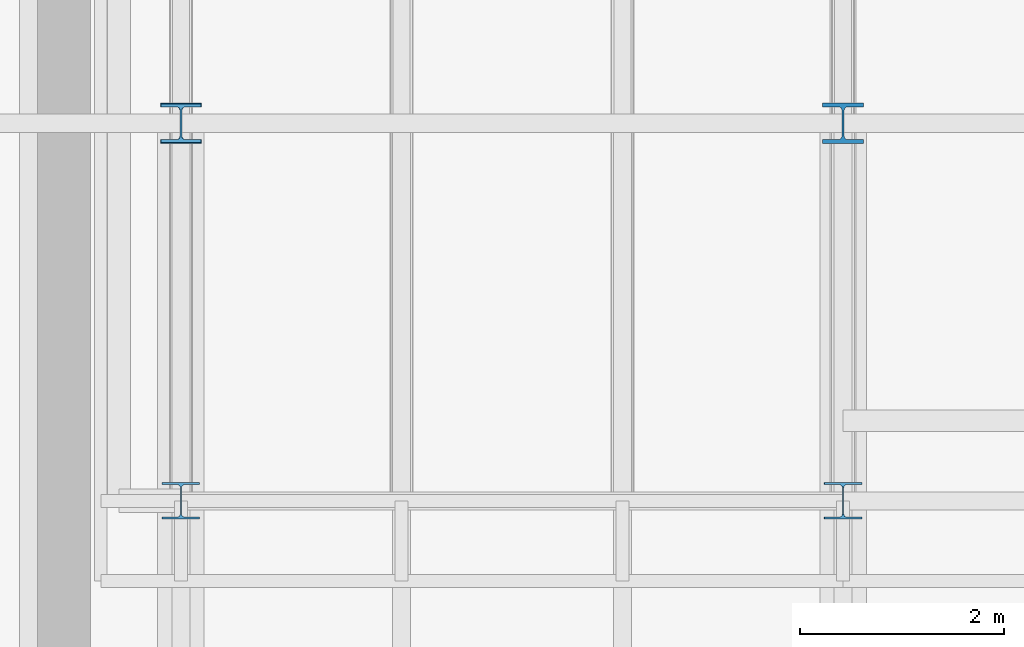
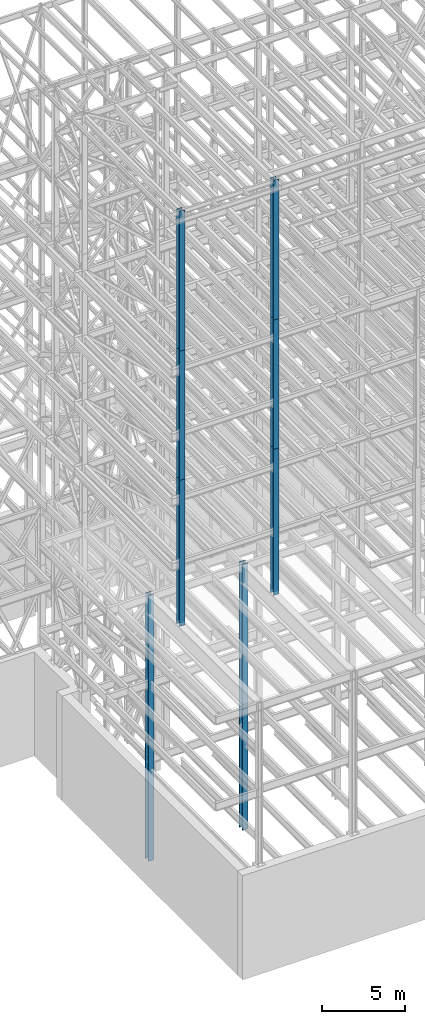
# One storey, part 2 of 150: 10 columns.
"""IFC2X3 building model written with IfcOpenShell, lengths in millimetres."""

from ifc_helpers import new_model, si_unit, frame, origin_with_axes, origin_2d_with_axis, place, context, subcontext, project, spatial, i_section, extrude, material, type_object, element, save


model = new_model("IFC2X3")

# Units and contexts
model_context = context("Model", 3, precision=1e-05, world=origin_with_axes())
body_context = subcontext(model_context, "Body", "Model", "MODEL_VIEW")
ifc_project = project(units=[si_unit("LENGTHUNIT", "METRE", prefix="MILLI"), si_unit("AREAUNIT", "SQUARE_METRE"), si_unit("VOLUMEUNIT", "CUBIC_METRE"), si_unit("MASSUNIT", "GRAM", prefix="KILO"), si_unit("TIMEUNIT", "SECOND"), si_unit("PLANEANGLEUNIT", "RADIAN"), si_unit("SOLIDANGLEUNIT", "STERADIAN"), si_unit("THERMODYNAMICTEMPERATUREUNIT", "DEGREE_CELSIUS"), si_unit("LUMINOUSINTENSITYUNIT", "LUMEN")], contexts=[model_context])

# Site, building, storey
site_placement = place(None, origin_with_axes())
site = spatial("IfcSite", under=ifc_project, at=site_placement, CompositionType="ELEMENT")
building_placement = place(site_placement, origin_with_axes())
building = spatial("IfcBuilding", under=site, at=building_placement, Name="Undefined", CompositionType="ELEMENT")
storey_placement = place(building_placement, origin_with_axes())
storey = spatial("IfcBuildingStorey", under=building, at=storey_placement, Name="Undefined", CompositionType="ELEMENT", Elevation=0.0)

# Columns
ifc_material = material(Name="STEEL/A992")
column_type_1 = type_object("IfcColumnType", Name="W14X193", PredefinedType="NOTDEFINED")
column_1_placement = place(storey_placement, frame((11785.6, 13106.4, 24993.6), z_axis=(0.0, 0.0, 1.0), x_axis=(1.0, 0.0, 0.0)))
element("IfcColumn", 1, at=column_1_placement, inside=storey, type_object=column_type_1, material=ifc_material, Name="COLUMN", ObjectType="W14X193", context=body_context, shape_type="SweptSolid", body=[
    extrude(i_section(OverallWidth=400.05, OverallDepth=393.7, WebThickness=22.225, FlangeThickness=36.576, FilletRadius=33.2739, at=origin_2d_with_axis()), frame((0.0, 0.0, 10591.8), z_axis=(0.0, 0.0, -1.0), x_axis=(-1.0, 0.0, 0.0)), (0.0, 0.0, 1.0), 10591.8),
])
for number, where, z_axis, x_axis, name in (
    (2, (11785.6, 13106.4, 16154.4), (0.0, 0.0, 1.0), (1.0, 0.0, 0.0), "COLUMN"),
    (3, (5283.2, 13106.4, 16154.4), (0.0, 0.0, 1.0), (1.0, 0.0, 0.0), "COLUMN"),
):
    element("IfcColumn", number, at=place(storey_placement, frame(where, z_axis=z_axis, x_axis=x_axis)), inside=storey, type_object=column_type_1, material=ifc_material, Name=name, ObjectType="W14X193", context=body_context, shape_type="SweptSolid", body=[
        extrude(i_section(OverallWidth=400.05, OverallDepth=393.7, WebThickness=22.225, FlangeThickness=36.576, FilletRadius=33.2739, at=origin_2d_with_axis()), frame((0.0, 0.0, 8839.2), z_axis=(0.0, 0.0, -1.0), x_axis=(-1.0, 0.0, 0.0)), (0.0, 0.0, 1.0), 8839.20000000001),
    ])
column_type_2 = type_object("IfcColumnType", Name="W14X90", PredefinedType="NOTDEFINED")
column_2_placement = place(storey_placement, frame((11785.6, 9398.0, 55702.2), z_axis=(0.0, 0.0, 1.0), x_axis=(1.0, 0.0, 0.0)))
element("IfcColumn", 4, at=column_2_placement, inside=storey, type_object=column_type_2, material=ifc_material, Name="COLUMN", ObjectType="W14X90", context=body_context, shape_type="SweptSolid", body=[
    extrude(i_section(OverallWidth=368.3, OverallDepth=355.6, WebThickness=11.1125, FlangeThickness=18.034, FilletRadius=32.7659, at=origin_2d_with_axis()), frame((0.0, 0.0, 10210.8), z_axis=(0.0, 0.0, -1.0), x_axis=(-1.0, 0.0, 0.0)), (0.0, 0.0, 1.0), 10210.8),
])
column_3_placement = place(storey_placement, frame((11785.6, 9398.0, 46253.4), z_axis=(0.0, 0.0, 1.0), x_axis=(1.0, 0.0, 0.0)))
element("IfcColumn", 5, at=column_3_placement, inside=storey, type_object=column_type_2, material=ifc_material, Name="COLUMN", ObjectType="W14X90", context=body_context, shape_type="SweptSolid", body=[
    extrude(i_section(OverallWidth=368.3, OverallDepth=355.6, WebThickness=11.1125, FlangeThickness=18.034, FilletRadius=32.7659, at=origin_2d_with_axis()), frame((0.0, 0.0, 9448.8), z_axis=(0.0, 0.0, -1.0), x_axis=(-1.0, 0.0, 0.0)), (0.0, 0.0, 1.0), 9448.8),
])
column_4_placement = place(storey_placement, frame((5283.2, 9398.0, 55702.2), z_axis=(0.0, 0.0, 1.0), x_axis=(1.0, 0.0, 0.0)))
element("IfcColumn", 6, at=column_4_placement, inside=storey, type_object=column_type_2, material=ifc_material, Name="COLUMN", ObjectType="W14X90", context=body_context, shape_type="SweptSolid", body=[
    extrude(i_section(OverallWidth=368.3, OverallDepth=355.6, WebThickness=11.1125, FlangeThickness=18.034, FilletRadius=32.7659, at=origin_2d_with_axis()), frame((0.0, 0.0, 10210.8), z_axis=(0.0, 0.0, -1.0), x_axis=(-1.0, 0.0, 0.0)), (0.0, 0.0, 1.0), 10210.8),
])
column_5_placement = place(storey_placement, frame((5283.2, 9398.0, 46253.4), z_axis=(0.0, 0.0, 1.0), x_axis=(1.0, 0.0, 0.0)))
element("IfcColumn", 7, at=column_5_placement, inside=storey, type_object=column_type_2, material=ifc_material, Name="COLUMN", ObjectType="W14X90", context=body_context, shape_type="SweptSolid", body=[
    extrude(i_section(OverallWidth=368.3, OverallDepth=355.6, WebThickness=11.1125, FlangeThickness=18.034, FilletRadius=32.7659, at=origin_2d_with_axis()), frame((0.0, 0.0, 9448.8), z_axis=(0.0, 0.0, -1.0), x_axis=(-1.0, 0.0, 0.0)), (0.0, 0.0, 1.0), 9448.80000000001),
])
column_6_placement = place(storey_placement, frame((5283.2, 9398.0, 35585.4), z_axis=(0.0, 0.0, 1.0), x_axis=(1.0, 0.0, 0.0)))
element("IfcColumn", 8, at=column_6_placement, inside=storey, type_object=column_type_2, material=ifc_material, Name="COLUMN", ObjectType="W14X90", context=body_context, shape_type="SweptSolid", body=[
    extrude(i_section(OverallWidth=368.3, OverallDepth=355.6, WebThickness=11.1125, FlangeThickness=18.034, FilletRadius=32.7659, at=origin_2d_with_axis()), frame((0.0, 0.0, 10668.0), z_axis=(0.0, 0.0, -1.0), x_axis=(-1.0, 0.0, 0.0)), (0.0, 0.0, 1.0), 10668.0),
])
column_type_3 = type_object("IfcColumnType", Name="W14X99", PredefinedType="NOTDEFINED")
column_7_placement = place(storey_placement, frame((11785.6, 9398.0, 35585.4), z_axis=(0.0, 0.0, 1.0), x_axis=(1.0, 0.0, 0.0)))
element("IfcColumn", 9, at=column_7_placement, inside=storey, type_object=column_type_3, material=ifc_material, Name="COLUMN", ObjectType="W14X99", context=body_context, shape_type="SweptSolid", body=[
    extrude(i_section(OverallWidth=370.84, OverallDepth=358.775, WebThickness=12.6999, FlangeThickness=19.812, FilletRadius=32.5755, at=origin_2d_with_axis()), frame((0.0, 0.0, 10668.0), z_axis=(0.0, 0.0, -1.0), x_axis=(-1.0, 0.0, 0.0)), (0.0, 0.0, 1.0), 10668.0),
])
column_type_4 = type_object("IfcColumnType", Name="W14X145", PredefinedType="NOTDEFINED")
column_8_placement = place(storey_placement, frame((5283.2, 13106.4, 24993.6), z_axis=(0.0, 0.0, 1.0), x_axis=(1.0, 0.0, 0.0)))
element("IfcColumn", 10, at=column_8_placement, inside=storey, type_object=column_type_4, material=ifc_material, Name="COLUMN", ObjectType="W14X145", context=body_context, shape_type="SweptSolid", body=[
    extrude(i_section(OverallWidth=393.7, OverallDepth=374.65, WebThickness=17.4625, FlangeThickness=27.686, FilletRadius=32.6389, at=origin_2d_with_axis()), frame((0.0, 0.0, 10591.8), z_axis=(0.0, 0.0, -1.0), x_axis=(-1.0, 0.0, 0.0)), (0.0, 0.0, 1.0), 10591.8),
])

save(model, "model.ifc")
